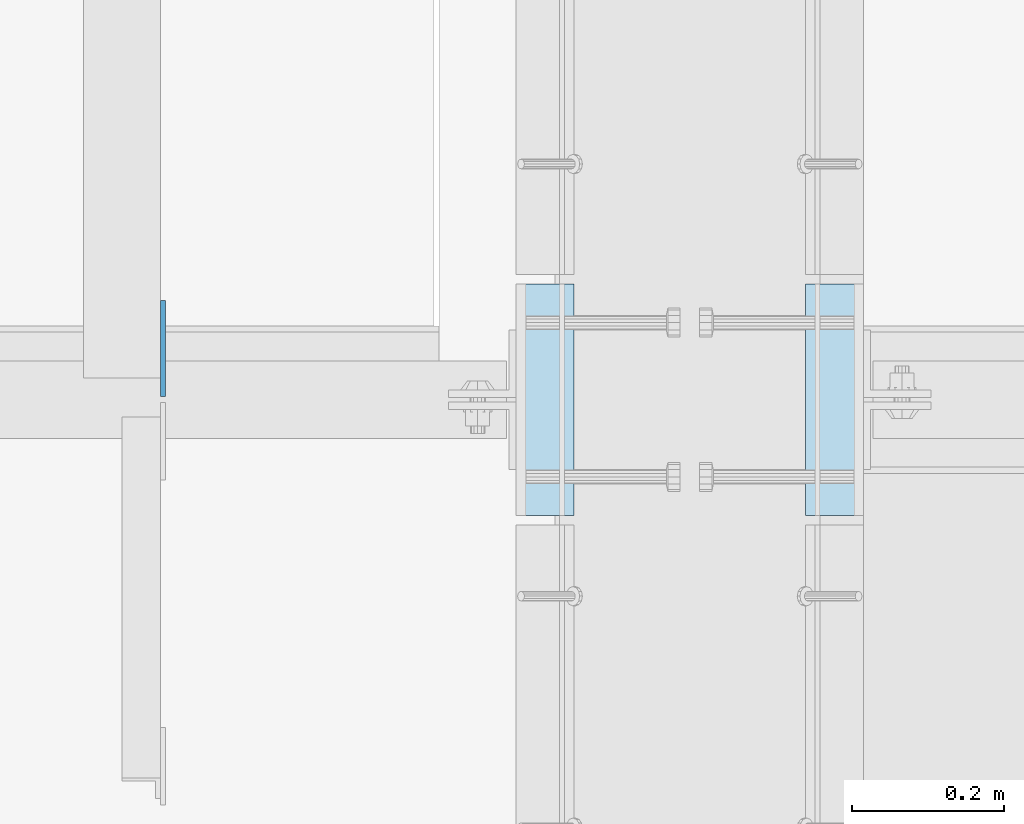
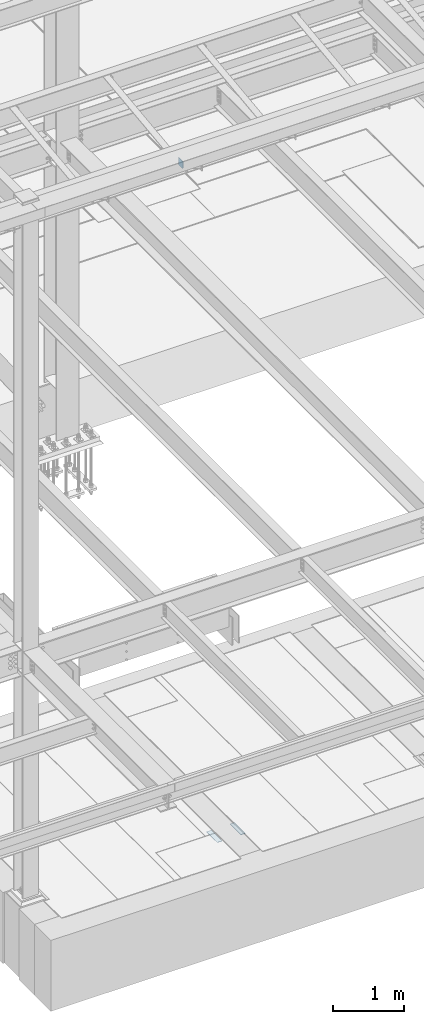
# One storey, part 3064 of 3843: 3 plates, 3 elements without a shape of their own.
"""IFC2X3 building model written with IfcOpenShell, lengths in millimetres."""

from ifc_helpers import new_model, si_unit, frame, origin_with_axes, place, context, subcontext, project, spatial, faceted_brep, material, type_object, element, aggregate, save


model = new_model("IFC2X3")

# Units and contexts
model_context = context("Model", 3, precision=1e-05, world=origin_with_axes())
body_context = subcontext(model_context, "Body", "Model", "MODEL_VIEW")
ifc_project = project(units=[si_unit("LENGTHUNIT", "METRE", prefix="MILLI"), si_unit("AREAUNIT", "SQUARE_METRE"), si_unit("VOLUMEUNIT", "CUBIC_METRE"), si_unit("MASSUNIT", "GRAM", prefix="KILO"), si_unit("TIMEUNIT", "SECOND"), si_unit("PLANEANGLEUNIT", "RADIAN"), si_unit("SOLIDANGLEUNIT", "STERADIAN"), si_unit("THERMODYNAMICTEMPERATUREUNIT", "DEGREE_CELSIUS"), si_unit("LUMINOUSINTENSITYUNIT", "LUMEN")], contexts=[model_context])

# Site, building, storey
site_placement = place(None, origin_with_axes())
site = spatial("IfcSite", under=ifc_project, at=site_placement, CompositionType="ELEMENT")
building_placement = place(site_placement, origin_with_axes())
building = spatial("IfcBuilding", under=site, at=building_placement, Name="Undefined", CompositionType="ELEMENT")
storey_placement = place(building_placement, origin_with_axes())
storey = spatial("IfcBuildingStorey", under=building, at=storey_placement, Name="Undefined", CompositionType="ELEMENT", Elevation=0.0)

# Assembly, plate
assembly_1_placement = place(storey_placement, origin_with_axes())
assembly_1 = element("IfcElementAssembly", 1, at=assembly_1_placement, inside=storey, Name="EMBED PLATE", AssemblyPlace="NOTDEFINED", PredefinedType="RIGID_FRAME")
ifc_material_1 = material(Name="STEEL/A36")
plate_type_1 = type_object("IfcPlateType", PredefinedType="NOTDEFINED")
plate_1_placement = place(assembly_1_placement, frame((58953.3999969482, 14846.3, 30426.025), z_axis=(0.0, 1.0, 0.0), x_axis=(1.0, 0.0, 0.0)))
plate_1 = element("IfcPlate", 2, at=plate_1_placement, type_object=plate_type_1, material=ifc_material_1, Name="PLATE", context=body_context, shape_type="Brep", body=[
    faceted_brep([(0.0, -3.17499999999927, 0.0), (0.0, -3.17499999999927, 304.800000000003), (0.0, 3.17499999999927, 304.800000000003), (0.0, 3.17499999999927, 0.0), (76.1999999999971, -3.17499999999927, 304.799999999996), (76.1999999999971, 3.17499999999927, 304.799999999996), (76.1999999999971, -3.17499999999927, 0.0), (76.1999999999971, 3.17499999999927, 0.0)], [[[0, 1, 2, 3]], [[1, 4, 5, 2]], [[4, 6, 7, 5]], [[6, 0, 3, 7]], [[5, 7, 3, 2]], [[6, 4, 1, 0]]]),
])
aggregate(assembly_1, [plate_1])

assembly_2_placement = place(storey_placement, origin_with_axes())
assembly_2 = element("IfcElementAssembly", 3, at=assembly_2_placement, inside=storey, Name="EMBED PLATE", AssemblyPlace="NOTDEFINED", PredefinedType="RIGID_FRAME")
plate_2_placement = place(assembly_2_placement, frame((59410.6000030518, 15151.1, 30426.025), z_axis=(0.0, -1.0, 0.0), x_axis=(-1.0, 0.0, 0.0)))
plate_2 = element("IfcPlate", 4, at=plate_2_placement, type_object=plate_type_1, material=ifc_material_1, Name="PLATE", context=body_context, shape_type="Brep", body=[
    faceted_brep([(0.0, -3.17499999999927, 0.0), (0.0, -3.17499999999927, 304.800000000003), (0.0, 3.17499999999927, 304.800000000003), (0.0, 3.17499999999927, 0.0), (76.1999999999971, -3.17499999999927, 304.799999999996), (76.1999999999971, 3.17499999999927, 304.799999999996), (76.1999999999971, -3.17499999999927, 0.0), (76.1999999999971, 3.17499999999927, 0.0)], [[[0, 1, 2, 3]], [[1, 4, 5, 2]], [[4, 6, 7, 5]], [[6, 0, 3, 7]], [[5, 7, 3, 2]], [[6, 4, 1, 0]]]),
])
aggregate(assembly_2, [plate_2])

assembly_3_placement = place(storey_placement, origin_with_axes())
assembly_3 = element("IfcElementAssembly", 5, at=assembly_3_placement, inside=storey, Name="BEAM", AssemblyPlace="NOTDEFINED", PredefinedType="RIGID_FRAME")
ifc_material_2 = material(Name="STEEL/A572-50")
plate_type_2 = type_object("IfcPlateType", PredefinedType="NOTDEFINED")
plate_3_placement = place(assembly_3_placement, frame((58488.2625, 15002.66875, 42202.1), z_axis=(0.0, 0.0, -1.0), x_axis=(0.0, 1.0, 0.0)))
plate_3 = element("IfcPlate", 6, at=plate_3_placement, type_object=plate_type_2, material=ifc_material_2, Name="PLATE", context=body_context, shape_type="Brep", body=[
    faceted_brep([(0.0, -3.17499999999927, 0.0), (0.0, -3.17500000000291, 107.950000000004), (0.0, 3.17500000000291, 107.950000000004), (0.0, 3.17499999999927, 0.0), (19.0500000000029, -3.17500000000291, 127.0), (19.0500000000029, 3.17500000000291, 127.0), (127.0, -3.17500000000291, 127.0), (127.0, 3.17500000000291, 127.0), (127.0, -3.17500000000291, 0.0), (127.0, 3.17500000000291, 0.0)], [[[0, 1, 2, 3]], [[1, 4, 5, 2]], [[4, 6, 7, 5]], [[6, 8, 9, 7]], [[8, 0, 3, 9]], [[5, 7, 9, 3, 2]], [[8, 6, 4, 1, 0]]]),
])
aggregate(assembly_3, [plate_3])

save(model, "model.ifc")
